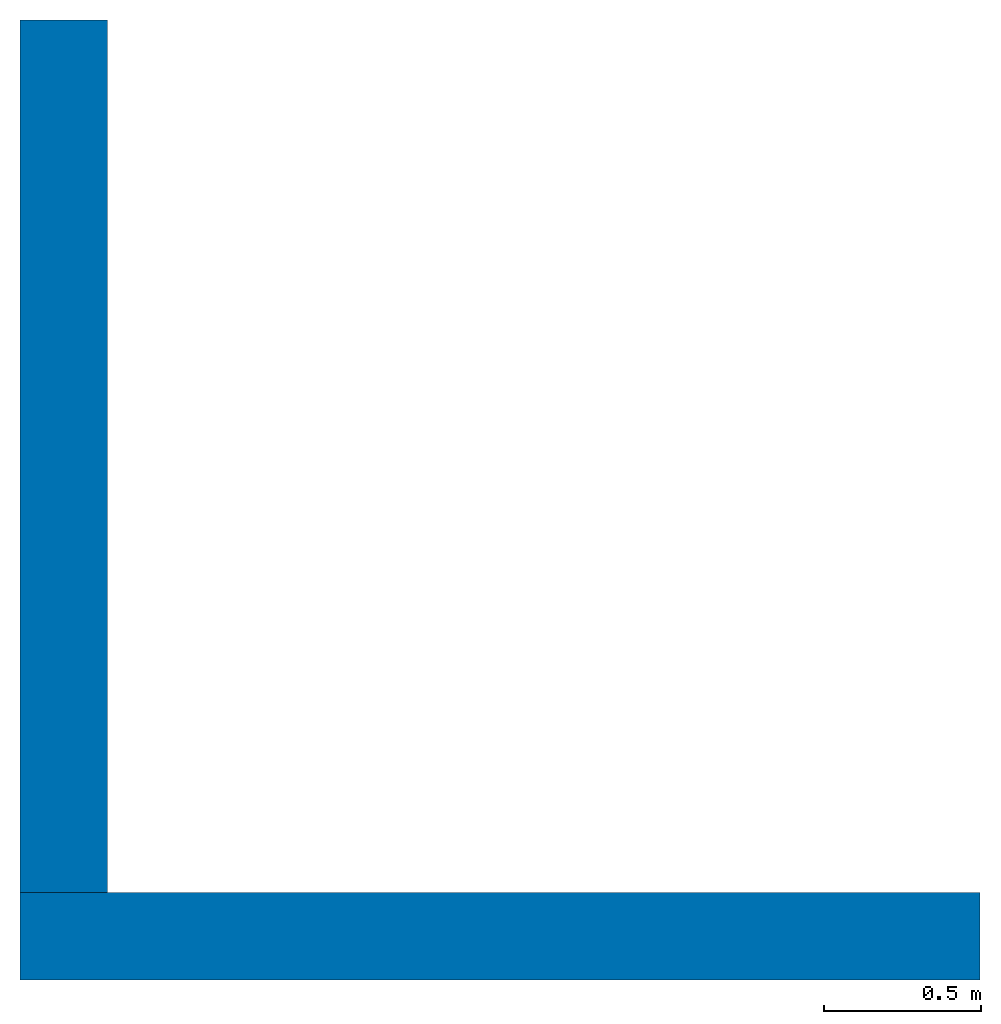
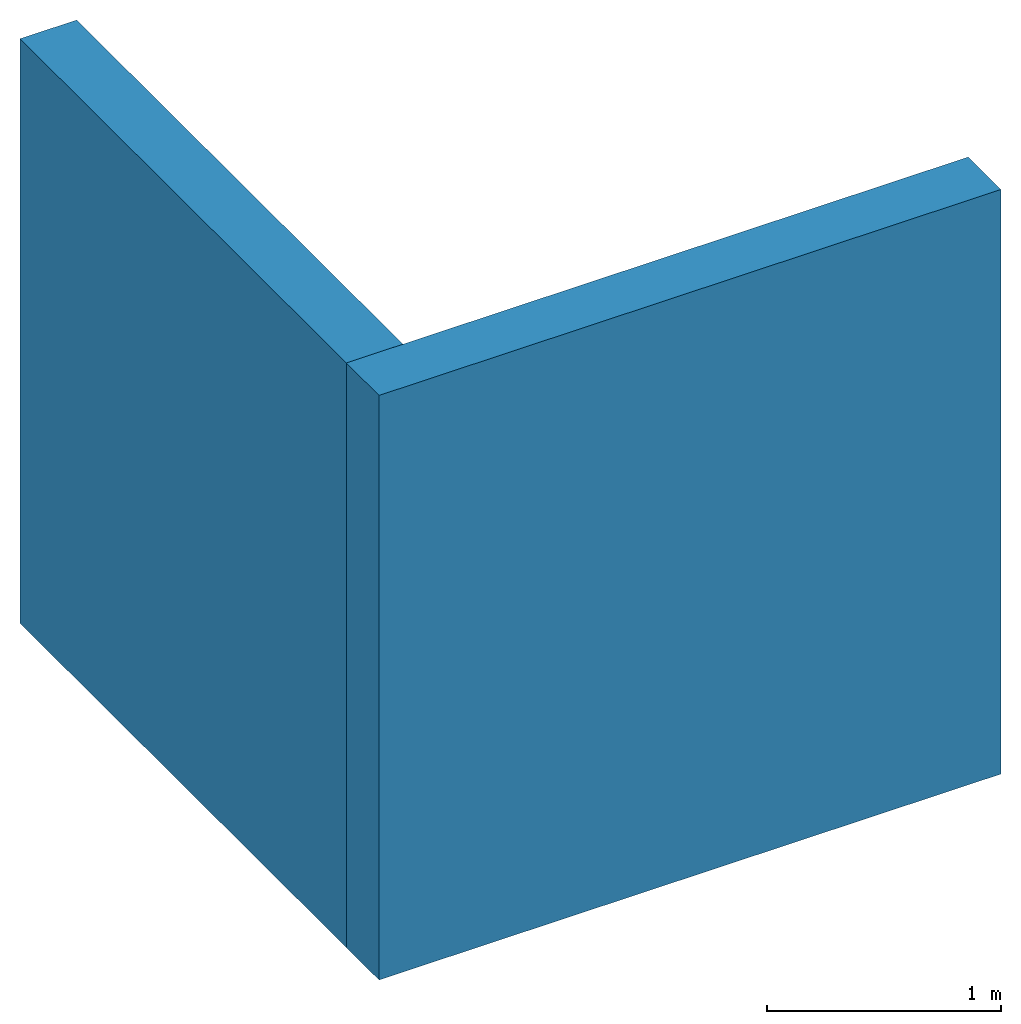
"""IFC4 building model written with IfcOpenShell, lengths in feet."""

from ifc_helpers import new_model, entity, si_unit, converted_unit, frame, origin_with_axes, origin_2d_with_axis, place, context, subcontext, project, spatial, indexed_curve, outline, extrude, material, layer, layer_set, layer_usage, type_object, element, save


model = new_model("IFC4")

# Units and contexts
model_context = context("Model", 3, precision=1e-05, world=origin_with_axes())
plan_context = context("Plan", 2, precision=1e-05, world=origin_2d_with_axis())
body_context = subcontext(model_context, "Body", "Model", "MODEL_VIEW")
ifc_project = project(units=[converted_unit("PLANEANGLEUNIT", "degree", entity("IfcReal", 0.0174532925199433), si_unit("PLANEANGLEUNIT", "RADIAN"), dimensions=[0, 0, 0, 0, 0, 0, 0]), converted_unit("AREAUNIT", "square foot", entity("IfcReal", 0.09290304), si_unit("AREAUNIT", "SQUARE_METRE"), dimensions=[2, 0, 0, 0, 0, 0, 0]), converted_unit("LENGTHUNIT", "foot", entity("IfcReal", 0.3048), si_unit("LENGTHUNIT", "METRE"), dimensions=[1, 0, 0, 0, 0, 0, 0]), converted_unit("VOLUMEUNIT", "cubic foot", entity("IfcReal", 0.0283168467116885), si_unit("VOLUMEUNIT", "CUBIC_METRE"), dimensions=[3, 0, 0, 0, 0, 0, 0])], contexts=[model_context, plan_context])

# Site, building, storeys
site_placement = place(None, origin_with_axes())
site = spatial("IfcSite", under=ifc_project, at=site_placement)
building_placement = place(site_placement, origin_with_axes())
building = spatial("IfcBuilding", under=site, at=building_placement, Name="Building")
storey_1_placement = place(building_placement, origin_with_axes())
storey_1 = spatial("IfcBuildingStorey", under=building, at=storey_1_placement, Name="1st Floor")
storey_2_placement = place(storey_1_placement, origin_with_axes())
storey_2 = spatial("IfcBuildingStorey", under=storey_1, at=storey_2_placement, Name="2nd Floor")

# Walls
ifc_material_1 = material(Name="BRICK - MODULAR - 3 1/2 x 2 1/4 x 7 1/2 - (4 x 2 2/3 x 8)", Category="Materials")
ifc_layer_1 = layer(ifc_material_1, 0.291666656732559, Name="BRICK", Category="Materials")
ifc_material_2 = material(Name="AIR GAP", Category="Materials")
ifc_layer_2 = layer(ifc_material_2, 0.0729166641831398, Name="AIR GAP", Category="Materials")
ifc_material_3 = material(Name="BUILDING WRAP OVER CDX SHEATHING", Category="Materials")
ifc_layer_3 = layer(ifc_material_3, 0.0416666679084301, Name="SHEATHING", Category="Materials")
ifc_material_4 = material(Category="Materials")
ifc_layer_4 = layer(ifc_material_4, 0.458333343267441, Name="STUD LAYER", Category="Materials")
ifc_material_5 = material(Category="Materials")
ifc_layer_5 = layer(ifc_material_5, 0.0520833320915699, Name="GYP. BD.", Category="Materials")
ifc_layer_set = layer_set([ifc_layer_1, ifc_layer_2, ifc_layer_3, ifc_layer_4, ifc_layer_5])
ifc_layer_usage_1 = layer_usage(ifc_layer_set, "AXIS2", "POSITIVE", 0.0)
wall_type = type_object("IfcWallType", PredefinedType="NOTDEFINED", material=ifc_layer_set)
wall_1_placement = place(storey_2_placement, frame((-0.406252611379611, 9.65625047683716, -9.77766482535935e-08), z_axis=(0.0, 0.0, 1.0), x_axis=(3.13916473260163e-07, -0.999999999999951, 0.0)))
element("IfcWall", 1, at=wall_1_placement, inside=storey_2, type_object=wall_type, material=ifc_layer_usage_1, Name="Wall", context=body_context, shape_type="SweptSolid", body=[
    extrude(outline(indexed_curve([(0.0, 0.0), (0.0, 0.91666666418314), (9.14583290947535, 0.91666666418314), (9.14583290947535, 0.0), (0.0, 0.0)], self_intersect=False)), origin_with_axes(), (0.0, 0.0, 1.0), 10.000000319143),
])
ifc_layer_usage_2 = layer_usage(ifc_layer_set, "AXIS2", "POSITIVE", 0.0)
wall_2_placement = place(storey_2_placement, frame((-0.406249458082705, -0.40624904253195, -9.77766424256512e-08), z_axis=(0.0, 0.0, 1.0), x_axis=(0.999999999999936, 3.57627868652321e-07, 0.0)))
element("IfcWall", 2, at=wall_2_placement, inside=storey_2, type_object=wall_type, material=ifc_layer_usage_2, Name="Wall", context=body_context, shape_type="SweptSolid", body=[
    extrude(outline(indexed_curve([(0.0, 0.0), (0.0, 0.91666666418314), (10.0625029530582, 0.91666666418314), (10.0625029530582, 0.0), (0.0, 0.0)], self_intersect=False)), origin_with_axes(), (0.0, 0.0, 1.0), 10.000000319143),
])

save(model, "model.ifc")
